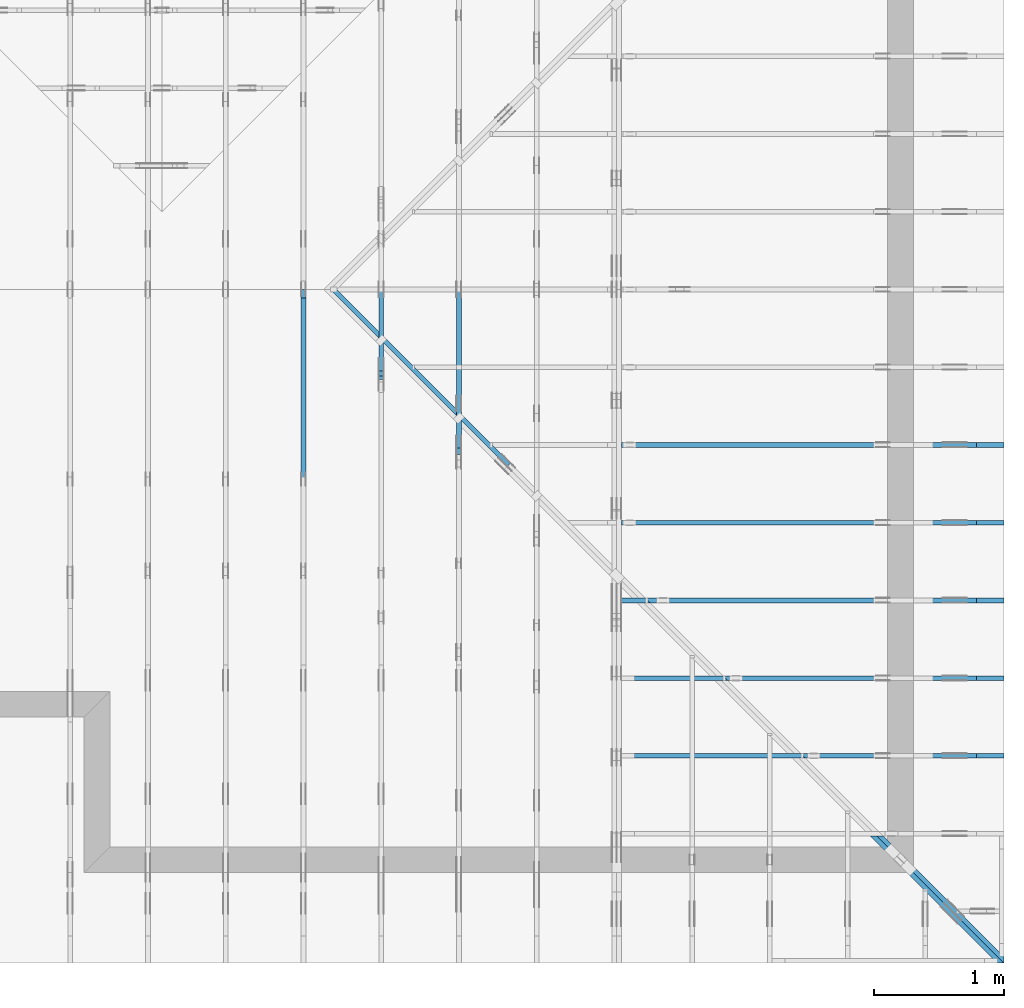
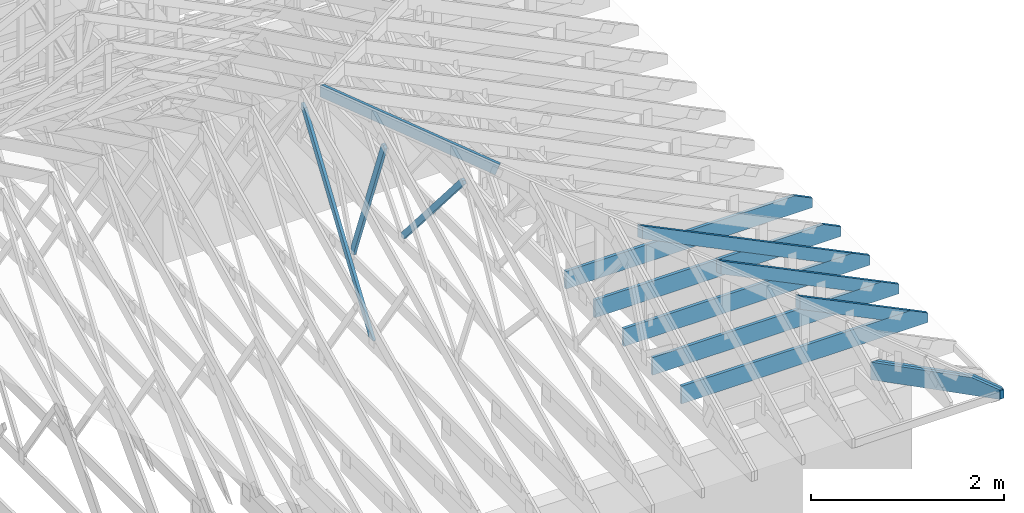
# One storey, part 31 of 159: 14 members, 9 elements without a shape of their own.
"""IFC2X3 building model written with IfcOpenShell, lengths in millimetres."""

from ifc_helpers import new_model, si_unit, frame, origin, origin_with_axes, origin_2d, place, context, project, spatial, faceted_brep, element, aggregate, save


model = new_model("IFC2X3")

# Units and contexts
model_context = context("Model", 3, precision=1e-05, world=origin())
plan_context = context("Plan", 2, precision=1e-05, world=origin_2d())
ifc_project = project(units=[si_unit("LENGTHUNIT", "METRE", prefix="MILLI"), si_unit("AREAUNIT", "SQUARE_METRE"), si_unit("VOLUMEUNIT", "CUBIC_METRE"), si_unit("SOLIDANGLEUNIT", "STERADIAN"), si_unit("PLANEANGLEUNIT", "RADIAN"), si_unit("MASSUNIT", "GRAM"), si_unit("TIMEUNIT", "SECOND"), si_unit("THERMODYNAMICTEMPERATUREUNIT", "DEGREE_CELSIUS"), si_unit("LUMINOUSINTENSITYUNIT", "LUMEN")], contexts=[model_context, plan_context])

# Site, building, storey
site_placement = place(None, origin_with_axes())
site = spatial("IfcSite", under=ifc_project, at=site_placement, CompositionType="ELEMENT")
building_placement = place(site_placement, origin_with_axes())
building = spatial("IfcBuilding", under=site, at=building_placement, Name="Plan 1", CompositionType="ELEMENT")
storey_placement = place(building_placement, origin_with_axes())
storey = spatial("IfcBuildingStorey", under=building, at=storey_placement, Name="Etasje 1", CompositionType="ELEMENT", Elevation=0.0)

# Assembly, member
assembly_1_placement = place(storey_placement, frame((16311.022261404749, -699.9989301294839, 1.1021457184401395e-15), z_axis=(1.0, -6.123031769111886e-17, 6.123031769111886e-17), x_axis=(6.123031769111886e-17, 1.0, 0.0)))
assembly_1 = element("IfcElementAssembly", 1, at=assembly_1_placement, inside=storey, Name="V8 (33)", AssemblyPlace="FACTORY", PredefinedType="TRUSS")
member_1_placement = place(assembly_1_placement, frame((4498.67108142577, 2130.2210148457375, -36.00000000000001), z_axis=(0.0, 0.0, 1.0), x_axis=(0.3523447959244446, -0.9358702606584748, 0.0)))
member_1 = element("IfcMember", 2, at=member_1_placement, Name="V8-D18", context=model_context, shape_type="Brep", body=[
    faceted_brep([(1796.5636561051333, 73.0000496749135, 36.0), (13.741922085409897, 73.0000496749135, 36.0), (0.00013095764188619796, 36.500186269624464, 36.0), (20.98472878272628, 0.0, 36.0), (1879.7702612393698, 0.0, 36.0), (1893.5120523671378, 36.500186269624464, 36.0), (13.741922085409897, 73.0000496749135, 1.6828445099525012e-15), (1796.5636561051333, 73.0000496749135, 2.2000832683127065e-13), (1893.5120523671378, 36.500186269624464, 2.318806890368047e-13), (1879.7702612393698, 0.0, 2.301978605640082e-13), (20.98472878272628, 0.0, 2.569803220056592e-15), (0.00013095764188619796, 36.500186269624464, 1.603715603354335e-20), (8.881784197001252e-15, 36.5000077407276, -4.930380657631324e-31), (1.0658141036401503e-14, 36.5000077407276, 36.0), (13.74184605694656, 73.00000774073031, 36.0), (13.741846056946557, 73.00000774073031, -8.874685183736383e-31), (20.98461344154066, 7.740730323391176e-06, -2.294449271127591e-31), (20.984613441540663, 7.740730325167533e-06, 36.0), (1.7763568394002505e-15, 36.5000077407276, 36.0), (0.0, 36.5000077407276, -2.9692241264586575e-31), (1879.7701898715775, 7.740729969603087e-06, 7.745997353463838e-29), (1879.7701898715775, 7.740729971807378e-06, 36.0), (20.98461344154066, 7.740730313249471e-06, 36.0), (20.98461344154066, 7.74073031104518e-06, 8.647161199168624e-31), (1893.512035928523, 36.50000774073044, 2.802596928649634e-45), (1893.512035928523, 36.50000774073044, 36.0), (1879.7701898715777, 7.740731234662235e-06, 36.0), (1879.7701898715777, 7.740731234662235e-06, 1.2621774483536192e-29), (1796.5636350748498, 73.00000774073135, 1.262177448353619e-29), (1796.5636350748498, 73.00000774073135, 36.0), (1893.5120359285231, 36.50000774073044, 36.0), (1893.5120359285231, 36.50000774073044, 1.262177448353619e-29), (13.741846056946542, 73.00000774073034, 7.888609052210118e-31), (13.741846056946542, 73.00000774073034, 36.0), (1796.5636350748493, 73.0000077407318, 36.0), (1796.5636350748493, 73.00000774073182, 3.549874073494553e-29)], [[[0, 1, 2, 3, 4, 5]], [[6, 7, 8, 9, 10, 11]], [[12, 13, 14, 15]], [[16, 17, 18, 19]], [[20, 21, 22, 23]], [[24, 25, 26, 27]], [[28, 29, 30, 31]], [[32, 33, 34, 35]]]),
])
aggregate(assembly_1, [member_1])

assembly_2_placement = place(storey_placement, frame((16875.02226140475, -699.9989301294827, 1.1021457184401395e-15), z_axis=(-1.0, 1.836909530733566e-16, 6.123031769111886e-17), x_axis=(-1.836909530733566e-16, -1.0, 0.0)))
assembly_2 = element("IfcElementAssembly", 3, at=assembly_2_placement, inside=storey, Name="V7 (32)", AssemblyPlace="FACTORY", PredefinedType="TRUSS")
member_2_placement = place(assembly_2_placement, frame((-3954.535228833248, 1874.2502165162878, -36.0), z_axis=(0.0, 0.0, 1.0), x_axis=(-0.6522779004060179, -0.7579799078088526, 0.0)))
member_2 = element("IfcMember", 4, at=member_2_placement, Name="V7-D16", context=model_context, shape_type="Brep", body=[
    faceted_brep([(1920.412304338743, 72.99998219927784, 36.0), (14.250152412409989, 72.99998219927784, 36.0), (0.0, 36.50008669603267, 36.0), (31.409983661153092, 9.719011995912297e-05, 36.0), (1909.4074505824096, 9.719011995912297e-05, 36.0), (1951.8222879998962, 36.50008669603267, 36.0), (14.250152412409989, 72.99998219927784, 1.745082718717455e-15), (1920.412304338743, 72.99998219927784, 2.3517491098518976e-13), (1951.8222879998962, 36.50008669603267, 2.390213975416803e-13), (1909.4074505824096, 9.719011995912297e-05, 2.3382724960190055e-13), (31.409983661153092, 9.719011995912297e-05, 3.846486556490513e-15), (0.0, 36.50008669603267, 0.0), (1.311915796975427e-05, 36.50002805649911, 6.902532920683853e-31), (1.3119157971530626e-05, 36.50002805649911, 36.0), (14.25009634671754, 73.00002805650549, 36.0), (14.250096346717536, 73.00002805650549, 1.1832913578315177e-30), (31.41000581096842, 2.8056506385709667e-05, -5.9164567891575885e-31), (31.41000581096842, 2.8056506387486024e-05, 36.0), (1.3119157983965124e-05, 36.500028056499104, 36.0), (1.3119157983965124e-05, 36.500028056499104, 0.0), (1909.4074116594843, 2.8056502683485437e-05, 5.929611680609957e-29), (1909.4074116594843, 2.805650268568973e-05, 36.0), (31.410005810968414, 2.8056506366654398e-05, 36.0), (31.410005810968414, 2.8056506364450106e-05, 9.754289738942568e-31), (1951.8222575676236, 36.50002805650479, 5.975159267300436e-29), (1951.8222575676236, 36.50002805650479, 36.0), (1909.4074116594848, 2.8056503083462303e-05, 36.0), (1909.4074116594848, 2.8056503083462303e-05, 4.678495196394631e-29), (1920.4122648758025, 73.00002805650388, 1.262177448353619e-29), (1920.4122648758025, 73.00002805650388, 36.0), (1951.8222575676232, 36.500028056505585, 36.0), (1951.8222575676232, 36.500028056505585, 0.0), (14.250096346717555, 73.00002805650547, 0.0), (14.250096346717555, 73.00002805650547, 36.0), (1920.4122648758025, 73.00002805650367, 36.0), (1920.4122648758025, 73.00002805650367, 7.888609052210118e-31)], [[[0, 1, 2, 3, 4, 5]], [[6, 7, 8, 9, 10, 11]], [[12, 13, 14, 15]], [[16, 17, 18, 19]], [[20, 21, 22, 23]], [[24, 25, 26, 27]], [[28, 29, 30, 31]], [[32, 33, 34, 35]]]),
])
aggregate(assembly_2, [member_2])

# Assembly, members
assembly_3_placement = place(storey_placement, frame((21100.012663101486, 918.0074014212582, 1.1021457184401395e-15), z_axis=(1.2246063538223773e-16, 1.0, 6.123031769111886e-17), x_axis=(-1.0, 1.2246063538223773e-16, 0.0)))
assembly_3 = element("IfcElementAssembly", 5, at=assembly_3_placement, inside=storey, Name="S19 (42)", AssemblyPlace="FACTORY", PredefinedType="TRUSS")
member_3_placement = place(assembly_3_placement, frame((276.06017491460835, 89.97845652009548, -36.00000021926103), z_axis=(0.0, 0.0, 1.0), x_axis=(0.8987940462991671, 0.438371146789077, 0.0)))
member_3 = element("IfcMember", 6, at=member_3_placement, Name="S19-O62", context=model_context, shape_type="Brep", body=[
    faceted_brep([(1508.591878700627, 147.99999481889887, 36.0000032464319), (1436.407454752265, 8.661231731821317e-10, 36.000000219260755), (1396.3537848112405, 3.1984228598958e-07, -2.2737367544323206e-13), (1468.5382087596026, 147.99999513787503, 3.027170805580681e-06), (8.098547726831384e-05, 148.00000000181896, 2.1926103244140904e-07), (8.098547726831384e-05, 148.00000000181896, 36.00000021926103), (1508.591877860477, 148.00000000181888, 36.00000021926103), (1468.538208884647, 148.00000000181888, 2.1926103244140904e-07), (0.0, 148.0000000009647, 2.1926103244140904e-07), (1468.5382080078123, 148.0000000009647, 2.1926121227953109e-07), (1396.3537826538086, 1.796507831386407e-09, 2.1926120343978047e-07), (303.44506835937494, 1.796507831386407e-09, 2.192610696014849e-07), (303.44502473359245, -8.526512829121202e-14, 2.1926103244140904e-07), (303.44502473359245, -8.526512829121202e-14, 36.00000021926103), (5.30204611450813e-05, 148.00000154094016, 36.00000021926103), (5.30204611450813e-05, 148.00000154094016, 2.1926103244140904e-07), (1436.4074538754264, 8.352513413628329e-10, 36.00000021926103), (303.444971423034, 8.354594563210309e-10, 36.00000021926103), (303.444971423034, 8.35457252029594e-10, 2.1926103244140904e-07), (1396.3537848995963, 8.352564945680242e-10, 2.1926103244140904e-07), (1508.591880106269, 148.0000000008662, 36.00000021926103), (0.00010611945259597633, 148.0000000008662, 36.00000021926103), (303.445052408515, 0.0, 36.00000021926103), (1436.4074547522648, 0.0, 36.00000021926103)], [[[0, 1, 2, 3]], [[4, 5, 6, 7]], [[8, 9, 10, 11]], [[12, 13, 14, 15]], [[16, 17, 18, 19]], [[20, 21, 22, 23]]]),
])
member_4_placement = place(assembly_3_placement, frame((2953.4710103785837, 223.0, -36.0), z_axis=(0.0, 0.0, 1.0), x_axis=(-1.0, 1.2246063538223773e-16, 0.0)))
member_4 = element("IfcMember", 7, at=member_4_placement, Name="S19-U10", context=model_context, shape_type="Brep", body=[
    faceted_brep([(2953.4710103785947, 223.00000000000037, 36.0), (6.311295874183998e-05, 223.00000000000037, 36.0), (6.311295874183998e-05, 0.0, 36.0), (2742.289720705732, 0.0, 36.0), (2953.4700660270973, 102.9995422363285, 36.0), (6.311295874183998e-05, 223.00000000000037, 7.728853028378678e-21), (2953.4710103785947, 223.00000000000037, 3.616839365139823e-13), (2953.4700660270973, 102.9995422363285, 3.6168382086809796e-13), (2742.289720705732, 0.0, 3.358225415998032e-13), (6.311295874183998e-05, 0.0, 7.728853028378678e-21), (0.0, 0.0, 0.0), (2.204291436880279e-15, -2.6993892992798474e-31, 36.0), (2.951301312711929e-14, 223.0, 36.0), (2.7308721690239013e-14, 223.0, -1.6721217048316832e-30), (2742.2897146949763, -5.037338112955833e-13, 5.172702487036636e-29), (2742.2897146949763, -5.01529519858703e-13, 36.0), (4.049083948919771e-31, 2.204291436880279e-15, 36.0), (0.0, 0.0, 0.0), (2953.4700660271087, 102.99953940881801, 5.880623194680879e-29), (2953.4700660271087, 102.99953940881801, 36.0), (2742.2897146949767, -2.2737367544323206e-13, 36.0), (2742.2897146949767, -2.2737367544323206e-13, 4.546043208465161e-29), (2953.469255282577, 223.00000000000037, -1.0746508672931903e-19), (2953.469255282577, 223.00000000000037, 36.0), (2953.469255282577, 102.9995394088186, 36.0), (2953.469255282577, 102.9995394088186, -4.9642145206786636e-20), (0.0, 223.0, 0.0), (0.0, 223.0, 36.0), (2953.4710103785947, 223.00000000000048, 36.0), (2953.4710103785947, 223.00000000000048, 6.310887241768095e-30)], [[[0, 1, 2, 3, 4]], [[5, 6, 7, 8, 9]], [[10, 11, 12, 13]], [[14, 15, 16, 17]], [[18, 19, 20, 21]], [[22, 23, 24, 25]], [[26, 27, 28, 29]]]),
])
aggregate(assembly_3, [member_3, member_4])

# Assembly, member
assembly_4_placement = place(storey_placement, frame((21100.012663101486, 3318.0074014212582, 1.1021457184401395e-15), z_axis=(1.2246063538223773e-16, 1.0, 6.123031769111886e-17), x_axis=(-1.0, 1.2246063538223773e-16, 0.0)))
assembly_4 = element("IfcElementAssembly", 8, at=assembly_4_placement, inside=storey, Name="S15 (41)", AssemblyPlace="FACTORY", PredefinedType="TRUSS")
member_5_placement = place(assembly_4_placement, frame((2953.4710103785837, 223.0, -36.0), z_axis=(0.0, 0.0, 1.0), x_axis=(-1.0, 1.2246063538223773e-16, 0.0)))
member_5 = element("IfcMember", 9, at=member_5_placement, Name="S15-U10", context=model_context, shape_type="Brep", body=[
    faceted_brep([(2953.4710103785947, 223.00000000000037, 36.0), (6.311295874183998e-05, 223.00000000000037, 36.0), (6.311295874183998e-05, 0.0, 36.0), (2742.289720705732, 0.0, 36.0), (2953.4700660270973, 102.9995422363285, 36.0), (6.311295874183998e-05, 223.00000000000037, 7.728853028378678e-21), (2953.4710103785947, 223.00000000000037, 3.616839365139823e-13), (2953.4700660270973, 102.9995422363285, 3.6168382086809796e-13), (2742.289720705732, 0.0, 3.358225415998032e-13), (6.311295874183998e-05, 0.0, 7.728853028378678e-21), (0.0, 0.0, 0.0), (2.204291436880279e-15, -2.6993892992798474e-31, 36.0), (2.951301312711929e-14, 223.0, 36.0), (2.7308721690239013e-14, 223.0, -1.6721217048316832e-30), (2742.2897146949763, -5.037338112955833e-13, 5.172702487036636e-29), (2742.2897146949763, -5.01529519858703e-13, 36.0), (4.049083948919771e-31, 2.204291436880279e-15, 36.0), (0.0, 0.0, 0.0), (2953.4700660271087, 102.99953940797445, 4.3026404708613384e-30), (2953.4700660271087, 102.99953940797445, 36.0), (2742.2897146949763, 0.0, 36.0), (2742.2897146949763, 0.0, 5.0266658494811856e-30), (2953.4692552825763, 223.00000000000037, -1.0746508677980613e-19), (2953.4692552825763, 223.00000000000037, 36.0), (2953.4692552825763, 102.9995394079746, 36.0), (2953.4692552825763, 102.9995394079746, -4.9642145257273734e-20), (0.0, 223.0, 0.0), (0.0, 223.0, 36.0), (2953.4710103785947, 223.00000000000048, 36.0), (2953.4710103785947, 223.00000000000048, 6.310887241768095e-30)], [[[0, 1, 2, 3, 4]], [[5, 6, 7, 8, 9]], [[10, 11, 12, 13]], [[14, 15, 16, 17]], [[18, 19, 20, 21]], [[22, 23, 24, 25]], [[26, 27, 28, 29]]]),
])
aggregate(assembly_4, [member_5])

# Assembly, members
assembly_5_placement = place(storey_placement, frame((21100.012663101486, 1518.0074014212582, 1.1021457184401395e-15), z_axis=(1.2246063538223773e-16, 1.0, 6.123031769111886e-17), x_axis=(-1.0, 1.2246063538223773e-16, 0.0)))
assembly_5 = element("IfcElementAssembly", 10, at=assembly_5_placement, inside=storey, Name="S18 (40)", AssemblyPlace="FACTORY", PredefinedType="TRUSS")
member_6_placement = place(assembly_5_placement, frame((276.06014433177796, 89.97844160385273, -36.00000021991139), z_axis=(0.0, 0.0, 1.0), x_axis=(0.8987940462991671, 0.4383711467890766, 0.0)))
member_6 = element("IfcMember", 11, at=member_6_placement, Name="S18-O53", context=model_context, shape_type="Brep", body=[
    faceted_brep([(2176.1530770109816, 147.9999948189307, 36.000003245929975), (2103.9686530636636, 3.8954794945311733e-10, 36.00000021991116), (2063.9149831232235, 3.1851800486037973e-07, -1.1368683772161603e-13), (2136.099407070542, 147.99999513705967, 3.0260187031672103e-06), (-8.2448119293684e-40, 148.00000000134236, 2.1991139220745026e-07), (-1.3496946578847356e-31, 148.00000000134236, 36.00000021991139), (2176.153076171875, 148.00000000134222, 36.00000021991139), (2136.099407196045, 148.00000000134222, 2.1991139220745026e-07), (4.1086544854351814e-05, 147.9999999993315, 2.199113922074553e-07), (2136.09940632092, 147.9999999993315, 2.199116537955408e-07), (2063.914980966916, 1.3052954273007344e-09, 2.199116449557902e-07), (303.44510944591974, 1.3052954273007344e-09, 2.1991142936753118e-07), (303.4450587601088, -7.105427357601002e-14, 2.1991139220745026e-07), (303.4450587601088, -7.105427357601002e-14, 36.00000021991139), (8.704697736305889e-05, 148.00000154093993, 36.00000021991139), (8.704697736305889e-05, 148.00000154093993, 2.1991139220745026e-07), (2103.968652188552, 3.805505774650925e-10, 36.00000021991139), (303.44501250959655, 3.8088131736849623e-10, 36.00000021991139), (303.44501250959655, 3.8099901716371887e-10, 2.1991139220745026e-07), (2063.914983212722, 3.806756347569434e-10, 2.1991139220745026e-07), (2176.1530784176666, 148.00000000038966, 36.00000021991139), (0.0001472042878845059, 148.00000000038966, 36.00000021991139), (303.4450934933504, 1.1368683772161603e-13, 36.00000021991139), (2103.968653063663, 1.1368683772161603e-13, 36.00000021991139)], [[[0, 1, 2, 3]], [[4, 5, 6, 7]], [[8, 9, 10, 11]], [[12, 13, 14, 15]], [[16, 17, 18, 19]], [[20, 21, 22, 23]]]),
])
member_7_placement = place(assembly_5_placement, frame((2953.4710103785837, 223.0, -36.0), z_axis=(0.0, 0.0, 1.0), x_axis=(-1.0, 1.2246063538223773e-16, 0.0)))
member_7 = element("IfcMember", 12, at=member_7_placement, Name="S18-U10", context=model_context, shape_type="Brep", body=[
    faceted_brep([(2953.4710103785947, 223.00000000000037, 36.0), (6.311295874183998e-05, 223.00000000000037, 36.0), (6.311295874183998e-05, 0.0, 36.0), (2742.289720705732, 0.0, 36.0), (2953.4700660270973, 102.9995422363285, 36.0), (6.311295874183998e-05, 223.00000000000037, 7.728853028378678e-21), (2953.4710103785947, 223.00000000000037, 3.616839365139823e-13), (2953.4700660270973, 102.9995422363285, 3.6168382086809796e-13), (2742.289720705732, 0.0, 3.358225415998032e-13), (6.311295874183998e-05, 0.0, 7.728853028378678e-21), (0.0, 0.0, 0.0), (2.204291436880279e-15, -2.6993892992798474e-31, 36.0), (2.951301312711929e-14, 223.0, 36.0), (2.7308721690239013e-14, 223.0, -1.6721217048316832e-30), (2742.2897146949763, -5.037338112955833e-13, 5.172702487036636e-29), (2742.2897146949763, -5.01529519858703e-13, 36.0), (4.049083948919771e-31, 2.204291436880279e-15, 36.0), (0.0, 0.0, 0.0), (2953.4700660271083, 102.9995394088487, -7.573064690121713e-29), (2953.4700660271083, 102.9995394088487, 36.0), (2742.289714694976, 1.1368683772161603e-12, 36.0), (2742.289714694976, 1.1368683772161603e-12, -6.310887241768094e-29), (2953.4692552825763, 223.00000000000037, -1.0746508677980613e-19), (2953.4692552825763, 223.00000000000037, 36.0), (2953.4692552825763, 102.99953940884771, 36.0), (2953.4692552825763, 102.99953940884771, -4.9642145257273734e-20), (0.0, 223.0, 0.0), (0.0, 223.0, 36.0), (2953.4710103785947, 223.00000000000048, 36.0), (2953.4710103785947, 223.00000000000048, 6.310887241768095e-30)], [[[0, 1, 2, 3, 4]], [[5, 6, 7, 8, 9]], [[10, 11, 12, 13]], [[14, 15, 16, 17]], [[18, 19, 20, 21]], [[22, 23, 24, 25]], [[26, 27, 28, 29]]]),
])
aggregate(assembly_5, [member_6, member_7])

# Assembly, member
assembly_6_placement = place(storey_placement, frame((21100.012663101486, 2718.0074014212582, 1.1021457184401395e-15), z_axis=(1.2246063538223773e-16, 1.0, 6.123031769111886e-17), x_axis=(-1.0, 1.2246063538223773e-16, 0.0)))
assembly_6 = element("IfcElementAssembly", 13, at=assembly_6_placement, inside=storey, Name="S16 (39)", AssemblyPlace="FACTORY", PredefinedType="TRUSS")
member_8_placement = place(assembly_6_placement, frame((2953.4710103785837, 223.0, -36.0), z_axis=(0.0, 0.0, 1.0), x_axis=(-1.0, 1.2246063538223773e-16, 0.0)))
member_8 = element("IfcMember", 14, at=member_8_placement, Name="S16-U10", context=model_context, shape_type="Brep", body=[
    faceted_brep([(2953.4710103785947, 223.00000000000037, 36.0), (6.311295874183998e-05, 223.00000000000037, 36.0), (6.311295874183998e-05, 0.0, 36.0), (2742.289720705732, 0.0, 36.0), (2953.4700660270973, 102.9995422363285, 36.0), (6.311295874183998e-05, 223.00000000000037, 7.728853028378678e-21), (2953.4710103785947, 223.00000000000037, 3.616839365139823e-13), (2953.4700660270973, 102.9995422363285, 3.6168382086809796e-13), (2742.289720705732, 0.0, 3.358225415998032e-13), (6.311295874183998e-05, 0.0, 7.728853028378678e-21), (0.0, 0.0, 0.0), (2.204291436880279e-15, -2.6993892992798474e-31, 36.0), (2.951301312711929e-14, 223.0, 36.0), (2.7308721690239013e-14, 223.0, -1.6721217048316832e-30), (2742.2897146949763, -5.037338112955833e-13, 5.172702487036636e-29), (2742.2897146949763, -5.01529519858703e-13, 36.0), (4.049083948919771e-31, 2.204291436880279e-15, 36.0), (0.0, 0.0, 0.0), (2953.4700660271083, 102.9995394088487, -7.573064690121713e-29), (2953.4700660271083, 102.9995394088487, 36.0), (2742.289714694976, 1.1368683772161603e-12, 36.0), (2742.289714694976, 1.1368683772161603e-12, -6.310887241768094e-29), (2953.4692552825763, 223.00000000000037, -1.0746508677980613e-19), (2953.4692552825763, 223.00000000000037, 36.0), (2953.4692552825763, 102.99953940884771, 36.0), (2953.4692552825763, 102.99953940884771, -4.9642145257273734e-20), (0.0, 223.0, 0.0), (0.0, 223.0, 36.0), (2953.4710103785947, 223.00000000000048, 36.0), (2953.4710103785947, 223.00000000000048, 6.310887241768095e-30)], [[[0, 1, 2, 3, 4]], [[5, 6, 7, 8, 9]], [[10, 11, 12, 13]], [[14, 15, 16, 17]], [[18, 19, 20, 21]], [[22, 23, 24, 25]], [[26, 27, 28, 29]]]),
])
aggregate(assembly_6, [member_8])

# Assembly, members
assembly_7_placement = place(storey_placement, frame((21100.012663101486, 2118.007401421258, 1.1021457184401395e-15), z_axis=(1.2246063538223773e-16, 1.0, 6.123031769111886e-17), x_axis=(-1.0, 1.2246063538223773e-16, 0.0)))
assembly_7 = element("IfcElementAssembly", 15, at=assembly_7_placement, inside=storey, Name="S17 (37)", AssemblyPlace="FACTORY", PredefinedType="TRUSS")
member_9_placement = place(assembly_7_placement, frame((276.0601732671012, 89.97845571567825, -36.00000022055984), z_axis=(0.0, 0.0, 1.0), x_axis=(0.8987940462991671, 0.43837114678907707, 0.0)))
member_9 = element("IfcMember", 16, at=member_9_placement, Name="S17-O40", context=model_context, shape_type="Brep", body=[
    faceted_brep([(2843.71420910251, 147.99999482142823, 36.00000324541611), (2771.52978515625, 2.3703705664956942e-09, 36.000000220559514), (2731.476115216393, 3.1964509616955183e-07, -2.2737367544323206e-13), (2803.6605391626526, 147.99999513870375, 3.0248563689383445e-06), (9.693470417460048e-05, 147.99999999997533, 2.2055984771895965e-07), (9.693470417460048e-05, 147.99999999997533, 36.000000220559855), (2843.7142082628293, 147.99999999997516, 36.000000220559855), (2803.660539286999, 147.99999999997516, 2.2055984771895965e-07), (0.00013802299019971542, 148.00000000175027, 2.2055984771897656e-07), (2803.6605384136146, 148.00000000175027, 2.2056019105701057e-07), (2731.476113059611, 8.526512829121202e-14, 2.2056018221726e-07), (303.4449622417402, 8.526512829121202e-14, 2.2055988487902254e-07), (303.44502656699535, 7.857465789129492e-10, 2.2055984771895965e-07), (303.44502656699535, 7.857465789129492e-10, 36.00000022055985), (5.4853864078552306e-05, 148.000001541726, 36.00000022055985), (5.4853864078552306e-05, 148.000001541726, 2.2055984771895965e-07), (2771.529784282841, 2.344187317280263e-09, 36.00000022055985), (303.4451094476361, 2.344640682106449e-09, 36.00000022055985), (303.4451094476361, 2.344870292382554e-09, 2.2055984771895965e-07), (2731.476115307011, 2.344424285052996e-09, 2.2055984771895965e-07), (2843.714210510254, 148.0000000023709, 36.00000022055985), (0.0, 148.0000000023709, 36.00000022055985), (303.44506835937545, 7.858602657506708e-10, 36.00000022055985), (2771.5297851562505, 7.858602657506708e-10, 36.00000022055985)], [[[0, 1, 2, 3]], [[4, 5, 6, 7]], [[8, 9, 10, 11]], [[12, 13, 14, 15]], [[16, 17, 18, 19]], [[20, 21, 22, 23]]]),
])
member_10_placement = place(assembly_7_placement, frame((2953.4710103785837, 223.0, -36.0), z_axis=(0.0, 0.0, 1.0), x_axis=(-1.0, 1.2246063538223773e-16, 0.0)))
member_10 = element("IfcMember", 17, at=member_10_placement, Name="S17-U10", context=model_context, shape_type="Brep", body=[
    faceted_brep([(2953.4710103785947, 223.00000000000037, 36.0), (6.311295874183998e-05, 223.00000000000037, 36.0), (6.311295874183998e-05, 0.0, 36.0), (2742.289720705732, 0.0, 36.0), (2953.4700660270973, 102.9995422363285, 36.0), (6.311295874183998e-05, 223.00000000000037, 7.728853028378678e-21), (2953.4710103785947, 223.00000000000037, 3.616839365139823e-13), (2953.4700660270973, 102.9995422363285, 3.6168382086809796e-13), (2742.289720705732, 0.0, 3.358225415998032e-13), (6.311295874183998e-05, 0.0, 7.728853028378678e-21), (0.0, 0.0, 0.0), (2.204291436880279e-15, -2.6993892992798474e-31, 36.0), (2.951301312711929e-14, 223.0, 36.0), (2.7308721690239013e-14, 223.0, -1.6721217048316832e-30), (2742.2897146949763, -5.037338112955833e-13, 5.172702487036636e-29), (2742.2897146949763, -5.01529519858703e-13, 36.0), (4.049083948919771e-31, 2.204291436880279e-15, 36.0), (0.0, 0.0, 0.0), (2953.4700660271087, 102.99953940795899, 7.573064690121713e-29), (2953.4700660271087, 102.99953940795899, 36.0), (2742.2897146949767, -6.821210263296962e-13, 36.0), (2742.2897146949767, -6.821210263296962e-13, 6.310887241768094e-29), (2953.469255282577, 223.00000000000037, -1.0746508672931903e-19), (2953.469255282577, 223.00000000000037, 36.0), (2953.469255282577, 102.99953940796004, 36.0), (2953.469255282577, 102.99953940796004, -4.9642145206786636e-20), (0.0, 223.0, 0.0), (0.0, 223.0, 36.0), (2953.4710103785947, 223.00000000000048, 36.0), (2953.4710103785947, 223.00000000000048, 6.310887241768095e-30)], [[[0, 1, 2, 3, 4]], [[5, 6, 7, 8, 9]], [[10, 11, 12, 13]], [[14, 15, 16, 17]], [[18, 19, 20, 21]], [[22, 23, 24, 25]], [[26, 27, 28, 29]]]),
])
aggregate(assembly_7, [member_9, member_10])

assembly_8_placement = place(storey_placement, frame((21125.46850722421, -674.5430860067681, 2.204291436880279e-15), z_axis=(0.707106781186546, 0.707106781186549, 6.123031769111886e-17), x_axis=(-0.707106781186549, 0.707106781186546, 0.0)))
assembly_8 = element("IfcElementAssembly", 18, at=assembly_8_placement, inside=storey, Name="GR1 (35)", AssemblyPlace="FACTORY", PredefinedType="TRUSS")
member_11_placement = place(assembly_8_placement, frame((5468.934471170831, 1837.1506714817583, -36.00000195234122), z_axis=(0.0, 0.0, 1.0), x_axis=(0.9453579955214152, 0.32603413978252627, 0.0)))
member_11 = element("IfcMember", 19, at=member_11_placement, Name="GR1-O54.1", context=model_context, shape_type="Brep", body=[
    faceted_brep([(2044.9695853527853, 148.00000217906847, 3.895813392773562e-06), (2006.8887738170722, 147.9999982981385, 36.00000229172758), (1955.8466796874998, 5.297806637827307e-11, 36.00000195234168), (1993.927491223214, 2.5418040650038165e-07, 2.3739653443044517e-06), (0.00010288836165273096, 148.00000000101977, 1.952341222022369e-06), (0.00010288836165273096, 148.00000000101977, 36.00000195234123), (2006.8887747633617, 148.00000000102008, 36.00000195234123), (2044.9695853102367, 148.0000000010201, 1.952341222022369e-06), (0.00010423553885630099, 148.00000000276373, 1.9523412220223817e-06), (2044.969586657413, 148.00000000276373, 1.952341472450644e-06), (1993.9274914730868, 9.872564987745136e-10, 1.9523414661999965e-06), (0.00010423553885630099, 9.872564987745136e-10, 1.9523412220223817e-06), (5.277854052110342e-05, 3.784341515711276e-07, 1.8783537143463036e-06), (5.2778539612036656e-05, 3.784341515711276e-07, 36.00000195234122), (5.2778539630160816e-05, 148.00000315368356, 36.00000255341424), (5.2778540539227645e-05, 148.00000315368356, 4.576700956714107e-28), (1993.927491581545, -3.662664415611424e-13, 1.952341222022369e-06), (1955.84668103467, -8.047089732699638e-13, 36.00000195234122), (1.3471699276124127e-06, -4.45437632612807e-13, 36.00000195234122), (1.3471699276124127e-06, -5.208241530224082e-22, 1.952341222022369e-06), (2006.8887748718262, 148.0000000000532, 36.00000195234122), (0.0, 148.0000000000532, 36.00000195234122), (0.0, 2.763044903986156e-09, 36.00000195234122), (1955.846679687499, 2.763044903986156e-09, 36.00000195234122)], [[[0, 1, 2, 3]], [[4, 5, 6, 7]], [[8, 9, 10, 11]], [[12, 13, 14, 15]], [[16, 17, 18, 19]], [[20, 21, 22, 23]]]),
])
member_12_placement = place(assembly_8_placement, frame((1388.7666724153187, 223.00000146033165, -36.000001069748365), z_axis=(0.0, 0.0, 1.0), x_axis=(-1.0, -3.216285744678249e-16, 0.0)))
member_12 = element("IfcMember", 20, at=member_12_placement, Name="GR1-U18.1", context=model_context, shape_type="Brep", body=[
    faceted_brep([(2.273736755491112e-13, 1.4603316458305926e-06, 1.0697483645571992e-06), (36.000001069756316, 1.4603315934603736e-06, 36.00000213951264), (36.00000106975634, 223.0000014603316, 36.000002139512326), (4.4641929594988464e-13, 223.00000146033165, 1.0697482591984166e-06), (2.2737367544323206e-13, 223.00000146033128, 1.0697483645571992e-06), (36.00000000000023, 223.00000146033128, 36.000001069748365), (1352.7667236328127, 223.0000014603312, 36.000001069748365), (1388.7667236328127, 223.0000014603312, 1.0697483645571992e-06), (1352.7667236328127, 223.000001460317, 36.000001069748365), (36.00000000000023, 223.000001460317, 36.000001069748365), (36.0, 1.460330878444438e-06, 36.000001069748365), (1054.1112060546877, 1.460330878444438e-06, 36.000001069748365), (1352.7667236328127, 103.00000146033089, 36.000001069748365), (1388.7666734850563, 223.00000146009646, -1.1368683772161603e-11), (1352.7666724153028, 223.00000146009646, 36.00000106974301), (1352.7666724153028, 103.00000146009647, 36.00000106974301), (1388.7659856484943, 115.41540864088626, 0.0006878365508100615), (1054.1112060546875, 1.4603314521999004e-06, 1.0697483645571992e-06), (1054.1112060546875, 1.4603314224297687e-06, 36.000001069748365), (36.0, 1.4603316094475866e-06, 36.000001069748365), (-2.350988701644575e-38, 1.4603316458305926e-06, 1.0697483645571992e-06), (1388.7659843199576, 115.41540889855622, 0.0006891650980520582), (1352.766670781902, 103.00000089677087, 36.00000251959024), (1054.1112157078783, 6.821210263296962e-13, 36.000002519590225), (1054.1112157078783, 7.389644451905042e-13, 1.0697538073145552e-06), (2.2737367544323206e-13, 223.00000146033165, 1.0697483645571992e-06), (1388.7667236328127, 223.00000146033165, 1.0697485346264545e-06), (1388.7659912109377, 115.41540673376913, 1.069748534626365e-06), (1054.1112060546877, 1.4603313047700794e-06, 1.0697484936443273e-06), (2.2737367544323206e-13, 1.4603313047700794e-06, 1.0697483645571992e-06)], [[[0, 1, 2, 3]], [[4, 5, 6, 7]], [[8, 9, 10, 11, 12]], [[13, 14, 15, 16]], [[17, 18, 19, 20]], [[21, 22, 23, 24]], [[25, 26, 27, 28, 29]]]),
])
member_13_placement = place(assembly_8_placement, frame((1424.766723632813, 223.00000338444963, -72.00000132855277), z_axis=(0.0, 0.0, 1.0), x_axis=(-1.0, -3.216285744678249e-16, 0.0)))
member_13 = element("IfcMember", 21, at=member_13_placement, Name="GR1-U18.1", context=model_context, shape_type="Brep", body=[
    faceted_brep([(5.014773839889394e-05, 3.3844493101075064e-06, 2.587888093304084e-07), (36.00005121749428, 3.3844492577372876e-06, 36.00000132855287), (36.0000512174945, 223.00000338444926, 36.00000132855277), (5.0147738411882176e-05, 223.00000338444931, 2.5878849791424253e-07), (1090.111257272182, 3.3844494269759345e-06, 1.3285527700190869e-06), (1090.111257272182, 3.384449429180226e-06, 36.00000132855277), (36.0000512174945, 3.384449622810918e-06, 36.00000132855277), (5.1217494501543115e-05, 3.384449627219501e-06, 1.3285527700190869e-06), (1388.76672230426, 223.00000554923574, -2.2737367544323206e-13), (1424.7667236328282, 223.00000554923574, 36.00000132856803), (1424.7660355374524, 115.41541082267324, 35.99931323319231), (1388.76672230426, 103.00000364188709, -2.2737367544323206e-13), (5.1217499958511326e-05, 223.00000338444963, 1.3285527700190869e-06), (36.00005121749996, 223.00000338444963, 36.00000132855277), (1424.7667748503125, 223.00000338444954, 36.00000132855277), (1388.7667748503125, 223.00000338444954, 1.3285527700190869e-06), (0.0, 223.00000338444963, 1.3285527700190869e-06), (1388.7667236328125, 223.00000338444963, 1.3285529400883422e-06), (1388.7667236328125, 103.000003384435, 1.3285529400883422e-06), (1090.1112670898438, 3.384435018460863e-06, 1.3285529035148053e-06), (0.0, 3.384435018460863e-06, 1.3285527700190869e-06), (1424.7660371708682, 115.4154113860036, 35.99931468304496), (1090.1112613462817, -2.2737367544323206e-13, 36.00000132855278), (1090.1112613462817, -2.2737367544323206e-13, 1.328552770019087e-06), (1388.7667236328125, 103.00000338421773, 1.328552770019087e-06), (1424.766774850307, 223.00000338443462, 36.00000132855277), (36.0000512174945, 223.00000338443462, 36.00000132855277), (36.0000512174945, 3.3844492577372876e-06, 36.00000132855277), (1090.111257272182, 3.3844492577372876e-06, 36.00000132855277), (1424.766042428432, 115.41540865788674, 36.00000132855277)], [[[0, 1, 2, 3]], [[4, 5, 6, 7]], [[8, 9, 10, 11]], [[12, 13, 14, 15]], [[16, 17, 18, 19, 20]], [[21, 22, 23, 24]], [[25, 26, 27, 28, 29]]]),
])
aggregate(assembly_8, [member_11, member_12, member_13])

# Assembly, member
assembly_9_placement = place(storey_placement, frame((15675.02226140475, -699.9989301294845, 1.1021457184401395e-15), z_axis=(-1.0, 1.836909530733566e-16, 6.123031769111886e-17), x_axis=(-1.836909530733566e-16, -1.0, 0.0)))
assembly_9 = element("IfcElementAssembly", 22, at=assembly_9_placement, inside=storey, Name="T7 (111)", AssemblyPlace="FACTORY", PredefinedType="TRUSS")
member_14_placement = place(assembly_9_placement, frame((-5230.134200945327, 2470.9490997577877, -36.0), z_axis=(0.0, 0.0, 1.0), x_axis=(0.5642475050069341, -0.8256056886271133, 0.0)))
member_14 = element("IfcMember", 23, at=member_14_placement, Name="T7-D10", context=model_context, shape_type="Brep", body=[
    faceted_brep([(2593.4163311647476, 73.00019205185345, 36.0), (64.12142578857947, 73.00019205185345, 36.0), (0.0, 36.500098826461, 36.0), (53.40677111084369, 6.283484799496364e-05, 36.0), (2543.5254730981324, 6.283484799496364e-05, 36.0), (64.12142578857947, 73.00019205185345, 7.852350543684446e-15), (2593.4163311647476, 73.00019205185345, 3.1759141172510683e-13), (2543.5254730981324, 6.283484799496364e-05, 3.114817455465041e-13), (53.40677111084369, 6.283484799496364e-05, 6.540227123947657e-15), (0.0, 36.500098826461, 0.0), (8.990210517012542e-05, 36.5000938930789, 3.944304526105059e-31), (8.990210517190178e-05, 36.50009389307889, 36.0), (64.12149423251047, 73.00009389364551, 36.0), (64.12149423251047, 73.00009389364551, 7.888609052210118e-31), (53.40680834923477, 9.3893645480847e-05, 1.1832913578315177e-30), (53.40680834923477, 9.389364548439971e-05, 36.0), (8.990210517723085e-05, 36.50009389307888, 36.0), (8.990210517723085e-05, 36.500093893078876, 3.944304526105059e-31), (2543.5255372683005, 9.389364500212836e-05, 1.1393273801051142e-28), (2543.5255372683005, 9.389364500433265e-05, 36.0), (53.40680834923478, 9.389364546174493e-05, 36.0), (53.40680834923478, 9.389364545954064e-05, 2.3922645400816085e-30), (2593.4162640800278, 73.00009389364232, -5.048709793414476e-29), (2593.4162640800278, 73.00009389364232, 36.0), (2543.5255372683, 9.38936470902263e-05, 36.0), (2543.5255372683, 9.38936470902263e-05, -5.048709793414476e-29), (64.12149423251049, 73.00009389364551, 0.0), (64.12149423251049, 73.00009389364551, 36.0), (2593.416264080028, 73.00009389364254, 36.0), (2593.416264080028, 73.00009389364254, 4.1809627976713626e-29)], [[[0, 1, 2, 3, 4]], [[5, 6, 7, 8, 9]], [[10, 11, 12, 13]], [[14, 15, 16, 17]], [[18, 19, 20, 21]], [[22, 23, 24, 25]], [[26, 27, 28, 29]]]),
])
aggregate(assembly_9, [member_14])

save(model, "model.ifc")
